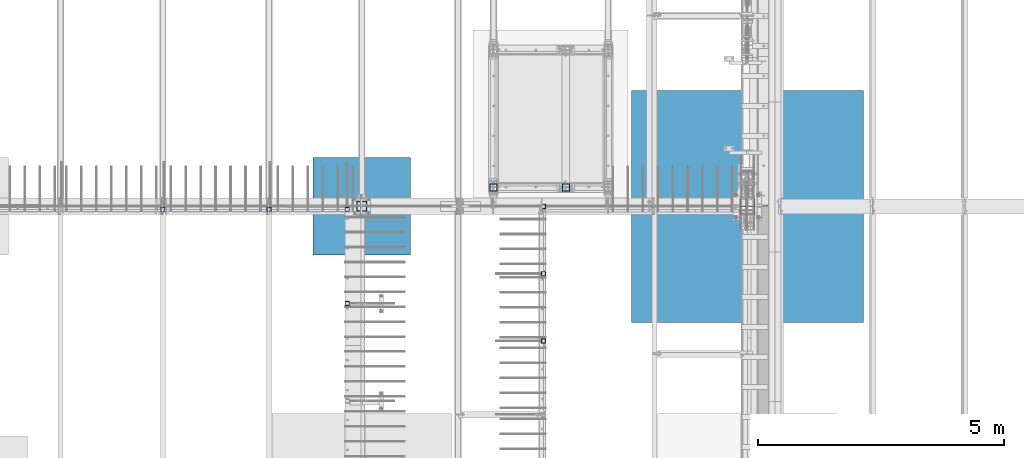
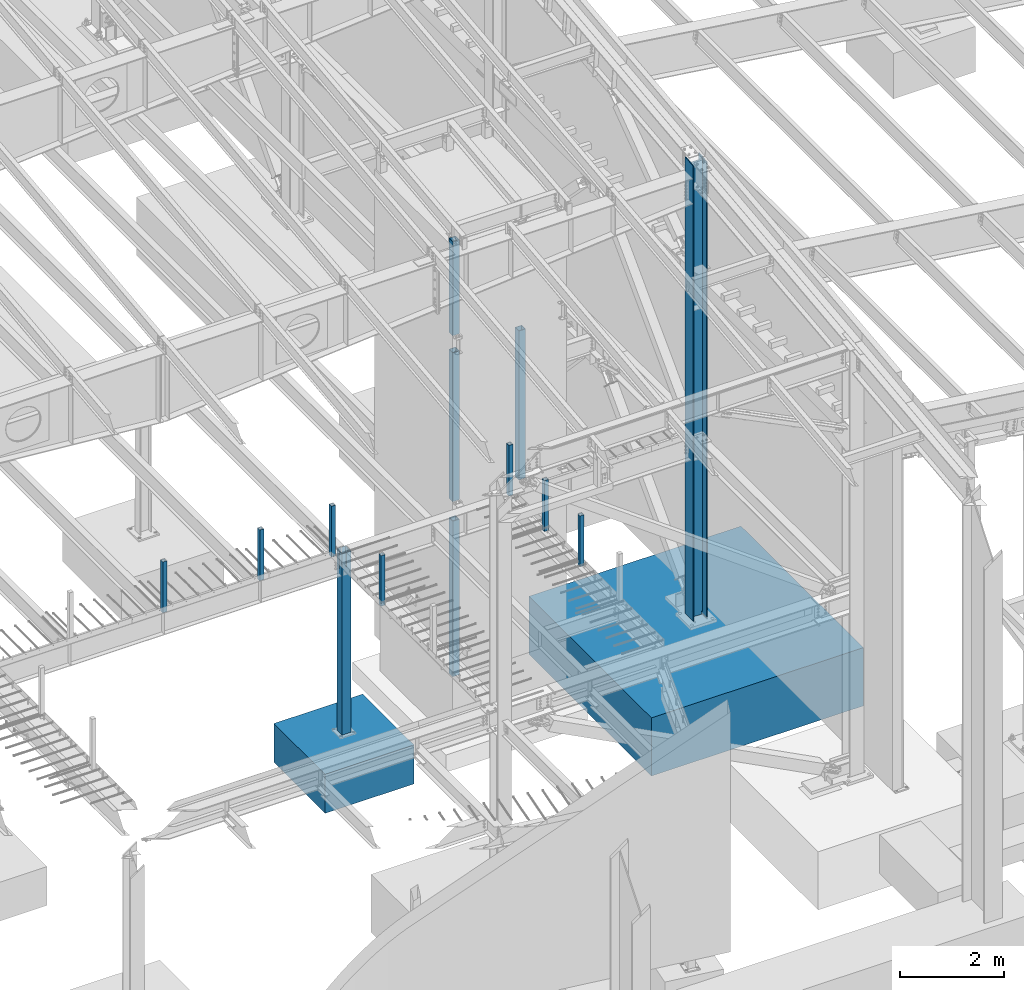
# One storey, part 355 of 1179: 15 columns, 15 elements without a shape of their own.
"""IFC2X3 building model written with IfcOpenShell, lengths in millimetres."""

from ifc_helpers import new_model, si_unit, frame, origin_with_axes, place, context, subcontext, project, spatial, faceted_brep, material, type_object, element, aggregate, save


model = new_model("IFC2X3")

# Units and contexts
model_context = context("Model", 3, precision=1e-05, world=origin_with_axes())
body_context = subcontext(model_context, "Body", "Model", "MODEL_VIEW")
ifc_project = project(units=[si_unit("LENGTHUNIT", "METRE", prefix="MILLI"), si_unit("AREAUNIT", "SQUARE_METRE"), si_unit("VOLUMEUNIT", "CUBIC_METRE"), si_unit("MASSUNIT", "GRAM", prefix="KILO"), si_unit("TIMEUNIT", "SECOND"), si_unit("PLANEANGLEUNIT", "RADIAN"), si_unit("SOLIDANGLEUNIT", "STERADIAN"), si_unit("THERMODYNAMICTEMPERATUREUNIT", "DEGREE_CELSIUS"), si_unit("LUMINOUSINTENSITYUNIT", "LUMEN")], contexts=[model_context])

# Site, building, storey
site_placement = place(None, origin_with_axes())
site = spatial("IfcSite", under=ifc_project, at=site_placement, CompositionType="ELEMENT")
building_placement = place(site_placement, origin_with_axes())
building = spatial("IfcBuilding", under=site, at=building_placement, Name="Undefined", CompositionType="ELEMENT")
storey_placement = place(building_placement, origin_with_axes())
storey = spatial("IfcBuildingStorey", under=building, at=storey_placement, Name="Undefined", CompositionType="ELEMENT", Elevation=0.0)

# Assembly, column
assembly_1_placement = place(storey_placement, origin_with_axes())
assembly_1 = element("IfcElementAssembly", 1, at=assembly_1_placement, inside=storey, Name="COLUMN", AssemblyPlace="NOTDEFINED", PredefinedType="RIGID_FRAME")
ifc_material_1 = material()
column_type_1 = type_object("IfcColumnType", Name="HSS6X6X3/8", PredefinedType="NOTDEFINED")
column_1_placement = place(assembly_1_placement, frame((19138.9, 11868.15, 4102.1), z_axis=(0.0, 1.0, 0.0), x_axis=(0.0, 0.0, 1.0)))
column_1 = element("IfcColumn", 2, at=column_1_placement, type_object=column_type_1, material=ifc_material_1, Name="COLUMN", ObjectType="HSS6X6X3/8", context=body_context, shape_type="Brep", body=[
    faceted_brep([(19.0500000000002, 66.6749999999993, -66.6749999999993), (19.0500000000002, -66.6749999999993, -66.6749999999993), (3524.25, -66.6749999999993, -66.6749999999993), (3524.25, 66.6749999999993, -66.6749999999993), (19.0500000000002, -66.6749999999993, 66.6749999999993), (3524.25, -66.6749999999993, 66.6749999999993), (19.0500000000002, 66.6749999999993, 66.6749999999993), (3524.25, 66.6749999999993, 66.6749999999993), (19.0500000000002, 76.2000000000007, -76.2000000000007), (19.0500000000002, 76.2000000000007, 76.2000000000007), (3524.25, 76.2000000000007, 76.2000000000007), (3524.25, 76.2000000000007, -76.2000000000007), (19.0500000000002, -76.2000000000007, 76.2000000000007), (3524.25, -76.2000000000007, 76.2000000000007), (19.0500000000002, -76.2000000000007, -76.2000000000007), (3524.25, -76.2000000000007, -76.2000000000007)], [[[0, 1, 2, 3]], [[1, 4, 5, 2]], [[4, 6, 7, 5]], [[6, 0, 3, 7]], [[8, 9, 10, 11]], [[9, 12, 13, 10]], [[12, 14, 15, 13]], [[14, 8, 11, 15]], [[13, 15, 11, 10], [5, 7, 3, 2]], [[14, 12, 9, 8], [6, 4, 1, 0]]]),
])
aggregate(assembly_1, [column_1])

assembly_2_placement = place(storey_placement, origin_with_axes())
assembly_2 = element("IfcElementAssembly", 3, at=assembly_2_placement, inside=storey, Name="COLUMN", AssemblyPlace="NOTDEFINED", PredefinedType="RIGID_FRAME")
column_2_placement = place(assembly_2_placement, frame((20612.1, 11868.15, 4102.1), z_axis=(0.0, 1.0, 0.0), x_axis=(0.0, 0.0, 1.0)))
column_2 = element("IfcColumn", 4, at=column_2_placement, type_object=column_type_1, material=ifc_material_1, Name="COLUMN", ObjectType="HSS6X6X3/8", context=body_context, shape_type="Brep", body=[
    faceted_brep([(19.0500000000002, 66.6749999999993, -66.6749999999993), (19.0500000000002, -66.6749999999993, -66.6749999999993), (3524.25, -66.6749999999993, -66.6749999999993), (3524.25, 66.6749999999993, -66.6749999999993), (19.0500000000002, -66.6749999999993, 66.6749999999993), (3524.25, -66.6749999999993, 66.6749999999993), (19.0500000000002, 66.6749999999993, 66.6749999999993), (3524.25, 66.6749999999993, 66.6749999999993), (19.0500000000002, 76.2000000000007, -76.2000000000007), (19.0500000000002, 76.2000000000007, 76.2000000000007), (3524.25, 76.2000000000007, 76.2000000000007), (3524.25, 76.2000000000007, -76.2000000000007), (19.0500000000002, -76.2000000000007, 76.2000000000007), (3524.25, -76.2000000000007, 76.2000000000007), (19.0500000000002, -76.2000000000007, -76.2000000000007), (3524.25, -76.2000000000007, -76.2000000000007)], [[[0, 1, 2, 3]], [[1, 4, 5, 2]], [[4, 6, 7, 5]], [[6, 0, 3, 7]], [[8, 9, 10, 11]], [[9, 12, 13, 10]], [[12, 14, 15, 13]], [[14, 8, 11, 15]], [[13, 15, 11, 10], [5, 7, 3, 2]], [[14, 12, 9, 8], [6, 4, 1, 0]]]),
])
aggregate(assembly_2, [column_2])

assembly_3_placement = place(storey_placement, origin_with_axes())
assembly_3 = element("IfcElementAssembly", 5, at=assembly_3_placement, inside=storey, Name="COLUMN", AssemblyPlace="NOTDEFINED", PredefinedType="RIGID_FRAME")
column_3_placement = place(assembly_3_placement, frame((19138.9, 11868.15, 8013.7), z_axis=(0.0, 1.0, 0.0), x_axis=(0.0, 0.0, 1.0)))
column_3 = element("IfcColumn", 6, at=column_3_placement, type_object=column_type_1, material=ifc_material_1, Name="COLUMN", ObjectType="HSS6X6X3/8", context=body_context, shape_type="Brep", body=[
    faceted_brep([(19.0500000000002, 66.6749999999993, -66.6749999999993), (19.0500000000002, -66.6749999999993, -66.6749999999993), (2231.40317592474, -66.6749999999993, -66.6749999999993), (2231.40317592474, 66.6749999999993, -66.6749999999993), (19.0500000000002, -66.6749999999993, 66.6749999999993), (2231.40317592474, -66.6749999999993, 66.6749999999993), (19.0500000000002, 66.6749999999993, 66.6749999999993), (2231.40317592474, 66.6749999999993, 66.6749999999993), (19.0500000000002, 76.2000000000007, -76.2000000000007), (19.0500000000002, 76.2000000000007, 76.2000000000007), (2231.40317592474, 76.2000000000007, 76.2000000000007), (2231.40317592474, 76.2000000000007, -76.2000000000007), (19.0500000000002, -76.2000000000007, 76.2000000000007), (2231.40317592474, -76.2000000000007, 76.2000000000007), (19.0500000000002, -76.2000000000007, -76.2000000000007), (2231.40317592474, -76.2000000000007, -76.2000000000007)], [[[0, 1, 2, 3]], [[1, 4, 5, 2]], [[4, 6, 7, 5]], [[6, 0, 3, 7]], [[8, 9, 10, 11]], [[9, 12, 13, 10]], [[12, 14, 15, 13]], [[14, 8, 11, 15]], [[13, 15, 11, 10], [5, 7, 3, 2]], [[14, 12, 9, 8], [6, 4, 1, 0]]]),
])
aggregate(assembly_3, [column_3])

assembly_4_placement = place(storey_placement, origin_with_axes())
assembly_4 = element("IfcElementAssembly", 7, at=assembly_4_placement, inside=storey, Name="COLUMN", AssemblyPlace="NOTDEFINED", PredefinedType="RIGID_FRAME")
column_type_2 = type_object("IfcColumnType", Name="HSS6X6X5/8", PredefinedType="NOTDEFINED")
column_4_placement = place(assembly_4_placement, frame((19138.9, 11868.15, 0.0), z_axis=(0.0, 1.0, 0.0), x_axis=(0.0, 0.0, 1.0)))
column_4 = element("IfcColumn", 8, at=column_4_placement, type_object=column_type_2, material=ifc_material_1, Name="COLUMN", ObjectType="HSS6X6X5/8", context=body_context, shape_type="Brep", body=[
    faceted_brep([(0.0, 60.3250000000007, -60.3250000000007), (2.71050543121376e-20, -60.3250000000007, -60.3250000000007), (3660.775, -60.325000001314, -60.3250000000007), (3660.775, 60.3249999986838, -60.3250000000007), (2.71050543121376e-20, -60.3250000000007, 60.3250000000007), (3660.775, -60.325000001314, 60.3250000000007), (0.0, 60.3250000000007, 60.3250000000007), (3660.775, 60.3249999986838, 60.3250000000007), (6.54836185276508e-11, 76.2, -76.1999999999998), (6.54836185276508e-11, 76.2, 76.1999999999998), (3660.775, 76.1999999986838, 76.2000000000007), (3660.775, 76.1999999986838, -76.2000000000007), (-6.54836185276508e-11, -76.2, 76.1999999999998), (3660.775, -76.200000001314, 76.2000000000007), (-6.54836185276508e-11, -76.2, -76.1999999999998), (3660.775, -76.200000001314, -76.2000000000007)], [[[0, 1, 2, 3]], [[1, 4, 5, 2]], [[4, 6, 7, 5]], [[6, 0, 3, 7]], [[8, 9, 10, 11]], [[9, 12, 13, 10]], [[12, 14, 15, 13]], [[14, 8, 11, 15]], [[13, 15, 11, 10], [5, 7, 3, 2]], [[14, 12, 9, 8], [6, 4, 1, 0]]]),
])
aggregate(assembly_4, [column_4])

assembly_5_placement = place(storey_placement, origin_with_axes())
assembly_5 = element("IfcElementAssembly", 9, at=assembly_5_placement, inside=storey, Name="COLUMN", AssemblyPlace="NOTDEFINED", PredefinedType="RIGID_FRAME")
column_type_3 = type_object("IfcColumnType", Name="HSS3-1/2X3-1/2X5/16", PredefinedType="NOTDEFINED")
column_5_placement = place(assembly_5_placement, frame((14566.9, 11420.475, 4102.1), z_axis=(0.0, 1.0, 0.0), x_axis=(0.0, 0.0, 1.0)))
column_5 = element("IfcColumn", 10, at=column_5_placement, type_object=column_type_3, material=ifc_material_1, Name="COLUMN", ObjectType="HSS3-1/2X3-1/2X5/16", context=body_context, shape_type="Brep", body=[
    faceted_brep([(0.0, 36.5125000000007, -36.5125000000007), (0.0, -36.5125000000007, -36.5125000000007), (1195.387, -36.5125000000007, -36.5125000000007), (1195.387, 36.5125000000007, -36.5125000000007), (0.0, -36.5125000000007, 36.5125000000007), (1195.387, -36.5125000000007, 36.5125000000007), (0.0, 36.5125000000007, 36.5125000000007), (1195.387, 36.5125000000007, 36.5125000000007), (0.0, 44.4500000000007, -44.4499999999998), (0.0, 44.4500000000007, 44.4500000000007), (1195.387, 44.4500000000007, 44.4500000000007), (1195.387, 44.4500000000007, -44.4500000000007), (0.0, -44.4500000000007, 44.4500000000007), (1195.387, -44.4500000000007, 44.4500000000007), (0.0, -44.4500000000007, -44.4500000000007), (1195.387, -44.4500000000007, -44.4500000000007)], [[[0, 1, 2, 3]], [[1, 4, 5, 2]], [[4, 6, 7, 5]], [[6, 0, 3, 7]], [[8, 9, 10, 11]], [[9, 12, 13, 10]], [[12, 14, 15, 13]], [[14, 8, 11, 15]], [[13, 15, 11, 10], [5, 7, 3, 2]], [[14, 12, 9, 8], [6, 4, 1, 0]]]),
])
aggregate(assembly_5, [column_5])

assembly_6_placement = place(storey_placement, origin_with_axes())
assembly_6 = element("IfcElementAssembly", 11, at=assembly_6_placement, inside=storey, Name="COLUMN", AssemblyPlace="NOTDEFINED", PredefinedType="RIGID_FRAME")
column_6_placement = place(assembly_6_placement, frame((12407.9, 11420.475, 4102.1), z_axis=(0.0, 1.0, 0.0), x_axis=(0.0, 0.0, 1.0)))
column_6 = element("IfcColumn", 12, at=column_6_placement, type_object=column_type_3, material=ifc_material_1, Name="COLUMN", ObjectType="HSS3-1/2X3-1/2X5/16", context=body_context, shape_type="Brep", body=[
    faceted_brep([(0.0, 36.5125000000007, -36.5125000000007), (0.0, -36.5125000000007, -36.5125000000007), (1195.387, -36.5125000000007, -36.5125000000007), (1195.387, 36.5125000000007, -36.5125000000007), (0.0, -36.5125000000007, 36.5125000000007), (1195.387, -36.5125000000007, 36.5125000000007), (0.0, 36.5125000000007, 36.5125000000007), (1195.387, 36.5125000000007, 36.5125000000007), (0.0, 44.4500000000007, -44.4499999999998), (0.0, 44.4500000000007, 44.4500000000007), (1195.387, 44.4500000000007, 44.4500000000007), (1195.387, 44.4500000000007, -44.4500000000007), (0.0, -44.4500000000007, 44.4500000000007), (1195.387, -44.4500000000007, 44.4500000000007), (0.0, -44.4500000000007, -44.4500000000007), (1195.387, -44.4500000000007, -44.4500000000007)], [[[0, 1, 2, 3]], [[1, 4, 5, 2]], [[4, 6, 7, 5]], [[6, 0, 3, 7]], [[8, 9, 10, 11]], [[9, 12, 13, 10]], [[12, 14, 15, 13]], [[14, 8, 11, 15]], [[13, 15, 11, 10], [5, 7, 3, 2]], [[14, 12, 9, 8], [6, 4, 1, 0]]]),
])
aggregate(assembly_6, [column_6])

assembly_7_placement = place(storey_placement, origin_with_axes())
assembly_7 = element("IfcElementAssembly", 13, at=assembly_7_placement, inside=storey, Name="COLUMN", AssemblyPlace="NOTDEFINED", PredefinedType="RIGID_FRAME")
column_7_placement = place(assembly_7_placement, frame((16163.925, 9499.6, 4108.45000000005), z_axis=(0.0, 1.0, 0.0), x_axis=(0.0, 0.0, 1.0)))
column_7 = element("IfcColumn", 14, at=column_7_placement, type_object=column_type_3, material=ifc_material_1, Name="COLUMN", ObjectType="HSS3-1/2X3-1/2X5/16", context=body_context, shape_type="Brep", body=[
    faceted_brep([(0.0, 36.5125000000007, -36.5125000000007), (0.0, -36.5125000000007, -36.5125000000007), (1189.03749999998, -36.5125000000007, -36.5124999999998), (1189.03749999998, 36.5125000000007, -36.5124999999998), (0.0, -36.5125000000007, 36.5125000000007), (1189.03749999998, -36.5125000000007, 36.5124999999998), (0.0, 36.5125000000007, 36.5125000000007), (1189.03749999998, 36.5125000000007, 36.5124999999998), (0.0, 44.4500000000007, -44.4499999999998), (0.0, 44.4500000000007, 44.4500000000007), (1189.03749999998, 44.4500000000007, 44.4499999999998), (1189.03749999998, 44.4500000000007, -44.4499999999998), (0.0, -44.4500000000007, 44.4500000000007), (1189.03749999998, -44.4500000000007, 44.4499999999998), (0.0, -44.4500000000007, -44.4500000000007), (1189.03749999998, -44.4500000000007, -44.4499999999998)], [[[0, 1, 2, 3]], [[1, 4, 5, 2]], [[4, 6, 7, 5]], [[6, 0, 3, 7]], [[8, 9, 10, 11]], [[9, 12, 13, 10]], [[12, 14, 15, 13]], [[14, 8, 11, 15]], [[13, 15, 11, 10], [5, 7, 3, 2]], [[14, 12, 9, 8], [6, 4, 1, 0]]]),
])
aggregate(assembly_7, [column_7])

assembly_8_placement = place(storey_placement, origin_with_axes())
assembly_8 = element("IfcElementAssembly", 15, at=assembly_8_placement, inside=storey, Name="COLUMN", AssemblyPlace="NOTDEFINED", PredefinedType="RIGID_FRAME")
column_8_placement = place(assembly_8_placement, frame((16163.925, 11420.475, 4102.1), z_axis=(0.0, 1.0, 0.0), x_axis=(0.0, 0.0, 1.0)))
column_8 = element("IfcColumn", 16, at=column_8_placement, type_object=column_type_3, material=ifc_material_1, Name="COLUMN", ObjectType="HSS3-1/2X3-1/2X5/16", context=body_context, shape_type="Brep", body=[
    faceted_brep([(0.0, 36.5125000000007, -36.5125000000007), (0.0, -36.5125000000007, -36.5125000000007), (1195.387, -36.5125000000007, -36.5125000000007), (1195.387, 36.5125000000007, -36.5125000000007), (0.0, -36.5125000000007, 36.5125000000007), (1195.387, -36.5125000000007, 36.5125000000007), (0.0, 36.5125000000007, 36.5125000000007), (1195.387, 36.5125000000007, 36.5125000000007), (0.0, 44.4500000000007, -44.4499999999998), (0.0, 44.4500000000007, 44.4500000000007), (1195.387, 44.4500000000007, 44.4500000000007), (1195.387, 44.4500000000007, -44.4500000000007), (0.0, -44.4500000000007, 44.4500000000007), (1195.387, -44.4500000000007, 44.4500000000007), (0.0, -44.4500000000007, -44.4500000000007), (1195.387, -44.4500000000007, -44.4500000000007)], [[[0, 1, 2, 3]], [[1, 4, 5, 2]], [[4, 6, 7, 5]], [[6, 0, 3, 7]], [[8, 9, 10, 11]], [[9, 12, 13, 10]], [[12, 14, 15, 13]], [[14, 8, 11, 15]], [[13, 15, 11, 10], [5, 7, 3, 2]], [[14, 12, 9, 8], [6, 4, 1, 0]]]),
])
aggregate(assembly_8, [column_8])

assembly_9_placement = place(storey_placement, origin_with_axes())
assembly_9 = element("IfcElementAssembly", 17, at=assembly_9_placement, inside=storey, Name="COLUMN", AssemblyPlace="NOTDEFINED", PredefinedType="RIGID_FRAME")
column_9_placement = place(assembly_9_placement, frame((20154.9, 8737.6, 4102.1), z_axis=(0.0, 1.0, 0.0), x_axis=(0.0, 0.0, 1.0)))
column_9 = element("IfcColumn", 18, at=column_9_placement, type_object=column_type_3, material=ifc_material_1, Name="COLUMN", ObjectType="HSS3-1/2X3-1/2X5/16", context=body_context, shape_type="Brep", body=[
    faceted_brep([(0.0, 36.5125000000007, -36.5125000000007), (0.0, -36.5125000000007, -36.5125000000007), (1195.387, -36.5125000000007, -36.5125000000007), (1195.387, 36.5125000000007, -36.5125000000007), (0.0, -36.5125000000007, 36.5125000000007), (1195.387, -36.5125000000007, 36.5125000000007), (0.0, 36.5125000000007, 36.5125000000007), (1195.387, 36.5125000000007, 36.5125000000007), (0.0, 44.4500000000007, -44.4499999999998), (0.0, 44.4500000000007, 44.4500000000007), (1195.387, 44.4500000000007, 44.4500000000007), (1195.387, 44.4500000000007, -44.4500000000007), (0.0, -44.4500000000007, 44.4500000000007), (1195.387, -44.4500000000007, 44.4500000000007), (0.0, -44.4500000000007, -44.4500000000007), (1195.387, -44.4500000000007, -44.4500000000007)], [[[0, 1, 2, 3]], [[1, 4, 5, 2]], [[4, 6, 7, 5]], [[6, 0, 3, 7]], [[8, 9, 10, 11]], [[9, 12, 13, 10]], [[12, 14, 15, 13]], [[14, 8, 11, 15]], [[13, 15, 11, 10], [5, 7, 3, 2]], [[14, 12, 9, 8], [6, 4, 1, 0]]]),
])
aggregate(assembly_9, [column_9])

assembly_10_placement = place(storey_placement, origin_with_axes())
assembly_10 = element("IfcElementAssembly", 19, at=assembly_10_placement, inside=storey, Name="COLUMN", AssemblyPlace="NOTDEFINED", PredefinedType="RIGID_FRAME")
column_10_placement = place(assembly_10_placement, frame((20154.9, 10109.2, 4102.1), z_axis=(0.0, 1.0, 0.0), x_axis=(0.0, 0.0, 1.0)))
column_10 = element("IfcColumn", 20, at=column_10_placement, type_object=column_type_3, material=ifc_material_1, Name="COLUMN", ObjectType="HSS3-1/2X3-1/2X5/16", context=body_context, shape_type="Brep", body=[
    faceted_brep([(0.0, 36.5125000000007, -36.5125000000007), (0.0, -36.5125000000007, -36.5125000000007), (1195.387, -36.5125000000007, -36.5125000000007), (1195.387, 36.5125000000007, -36.5125000000007), (0.0, -36.5125000000007, 36.5125000000007), (1195.387, -36.5125000000007, 36.5125000000007), (0.0, 36.5125000000007, 36.5125000000007), (1195.387, 36.5125000000007, 36.5125000000007), (0.0, 44.4500000000007, -44.4499999999998), (0.0, 44.4500000000007, 44.4500000000007), (1195.387, 44.4500000000007, 44.4500000000007), (1195.387, 44.4500000000007, -44.4500000000007), (0.0, -44.4500000000007, 44.4500000000007), (1195.387, -44.4500000000007, 44.4500000000007), (0.0, -44.4500000000007, -44.4500000000007), (1195.387, -44.4500000000007, -44.4500000000007)], [[[0, 1, 2, 3]], [[1, 4, 5, 2]], [[4, 6, 7, 5]], [[6, 0, 3, 7]], [[8, 9, 10, 11]], [[9, 12, 13, 10]], [[12, 14, 15, 13]], [[14, 8, 11, 15]], [[13, 15, 11, 10], [5, 7, 3, 2]], [[14, 12, 9, 8], [6, 4, 1, 0]]]),
])
aggregate(assembly_10, [column_10])

assembly_11_placement = place(storey_placement, origin_with_axes())
assembly_11 = element("IfcElementAssembly", 21, at=assembly_11_placement, inside=storey, Name="COLUMN", AssemblyPlace="NOTDEFINED", PredefinedType="RIGID_FRAME")
column_11_placement = place(assembly_11_placement, frame((20154.9, 11480.8, 4102.1), z_axis=(0.0, 1.0, 0.0), x_axis=(0.0, 0.0, 1.0)))
column_11 = element("IfcColumn", 22, at=column_11_placement, type_object=column_type_3, material=ifc_material_1, Name="COLUMN", ObjectType="HSS3-1/2X3-1/2X5/16", context=body_context, shape_type="Brep", body=[
    faceted_brep([(0.0, 36.5125000000007, -36.5125000000007), (0.0, -36.5125000000007, -36.5125000000007), (1195.387, -36.5125000000007, -36.5125000000007), (1195.387, 36.5125000000007, -36.5125000000007), (0.0, -36.5125000000007, 36.5125000000007), (1195.387, -36.5125000000007, 36.5125000000007), (0.0, 36.5125000000007, 36.5125000000007), (1195.387, 36.5125000000007, 36.5125000000007), (0.0, 44.4500000000007, -44.4499999999998), (0.0, 44.4500000000007, 44.4500000000007), (1195.387, 44.4500000000007, 44.4500000000007), (1195.387, 44.4500000000007, -44.4500000000007), (0.0, -44.4500000000007, 44.4500000000007), (1195.387, -44.4500000000007, 44.4500000000007), (0.0, -44.4500000000007, -44.4500000000007), (1195.387, -44.4500000000007, -44.4500000000007)], [[[0, 1, 2, 3]], [[1, 4, 5, 2]], [[4, 6, 7, 5]], [[6, 0, 3, 7]], [[8, 9, 10, 11]], [[9, 12, 13, 10]], [[12, 14, 15, 13]], [[14, 8, 11, 15]], [[13, 15, 11, 10], [5, 7, 3, 2]], [[14, 12, 9, 8], [6, 4, 1, 0]]]),
])
aggregate(assembly_11, [column_11])

assembly_12_placement = place(storey_placement, origin_with_axes())
assembly_12 = element("IfcElementAssembly", 23, at=assembly_12_placement, inside=storey, Name="FOOTING", AssemblyPlace="NOTDEFINED", PredefinedType="REINFORCEMENT_UNIT")
ifc_material_2 = material(Name="CONCRETE/3000")
column_type_4 = type_object("IfcColumnType", PredefinedType="NOTDEFINED")
column_12_placement = place(assembly_12_placement, frame((24307.8, 11480.8, -1727.2), z_axis=(-1.0, 0.0, 0.0), x_axis=(0.0, 0.0, 1.0)))
column_12 = element("IfcColumn", 24, at=column_12_placement, type_object=column_type_4, material=ifc_material_2, Name="FOOTING", context=body_context, shape_type="Brep", body=[
    faceted_brep([(0.0, 2362.2, -2362.2), (0.0, 2362.2, 2362.2), (1371.6, 2362.2, 2362.2), (1371.6, 2362.2, -2362.2), (0.0, -2362.2, 2362.2), (1371.6, -2362.2, 2362.2), (0.0, -2362.2, -2362.2), (1371.6, -2362.2, -2362.2)], [[[0, 1, 2, 3]], [[1, 4, 5, 2]], [[4, 6, 7, 5]], [[6, 0, 3, 7]], [[5, 7, 3, 2]], [[6, 4, 1, 0]]]),
])
aggregate(assembly_12, [column_12])

assembly_13_placement = place(storey_placement, origin_with_axes())
assembly_13 = element("IfcElementAssembly", 25, at=assembly_13_placement, inside=storey, Name="FOOTING", AssemblyPlace="NOTDEFINED", PredefinedType="REINFORCEMENT_UNIT")
column_type_5 = type_object("IfcColumnType", PredefinedType="NOTDEFINED")
column_13_placement = place(assembly_13_placement, frame((16459.2, 11480.8, -1168.4), z_axis=(-1.0, 0.0, 0.0), x_axis=(0.0, 0.0, 1.0)))
column_13 = element("IfcColumn", 26, at=column_13_placement, type_object=column_type_5, material=ifc_material_2, Name="FOOTING", context=body_context, shape_type="Brep", body=[
    faceted_brep([(0.0, 990.6, -990.599999999999), (0.0, 990.6, 990.6), (914.4, 990.6, 990.6), (914.4, 990.6, -990.599999999999), (0.0, -990.6, 990.6), (914.4, -990.6, 990.6), (0.0, -990.6, -990.599999999999), (914.4, -990.6, -990.599999999999)], [[[0, 1, 2, 3]], [[1, 4, 5, 2]], [[4, 6, 7, 5]], [[6, 0, 3, 7]], [[5, 7, 3, 2]], [[6, 4, 1, 0]]]),
])
aggregate(assembly_13, [column_13])

assembly_14_placement = place(storey_placement, origin_with_axes())
assembly_14 = element("IfcElementAssembly", 27, at=assembly_14_placement, inside=storey, Name="COLUMN", AssemblyPlace="NOTDEFINED", PredefinedType="RIGID_FRAME")
ifc_material_3 = material(Name="STEEL/A992")
column_type_6 = type_object("IfcColumnType", Name="W12X79", PredefinedType="NOTDEFINED")
column_14_placement = place(assembly_14_placement, frame((24307.8, 11480.8, -355.6), z_axis=(-1.0, 0.0, 0.0), x_axis=(0.0, 0.0, 1.0)))
column_14 = element("IfcColumn", 28, at=column_14_placement, type_object=column_type_6, material=ifc_material_3, Name="COLUMN", ObjectType="W12X79", context=body_context, shape_type="Brep", body=[
    faceted_brep([(160.223581529497, -153.987499999999, 157.1625), (160.223581529497, 153.987499999999, 157.1625), (149.225002356772, 153.987499999999, 138.1125), (149.225002356772, 6.35000012494493, 138.1125), (148.995793121516, 6.35000012313685, 137.715499999996), (148.995793121516, -6.34999999999854, 137.715499999996), (149.225002356772, -6.34999999999854, 138.1125), (149.225002356772, -153.987499999999, 138.1125), (188.913, -6.34999999999854, 137.715499999996), (188.913, 6.35000008947463, 137.715499999996), (208.49066058208, 6.35000008789211, 131.2871410688), (208.49066058208, -6.34999999999854, 131.2871410688), (212.873373738864, 6.35000008718271, 128.290736246858), (212.873373738864, -6.34999999999854, 128.290736246858), (214.971292158606, 6.35000008606585, 123.413713099926), (214.971292158606, -6.34999999999854, 123.413713099926), (214.132634973196, 6.3500000848835, 118.171264187733), (214.132634973196, -6.34999999999854, 118.171264187733), (210.617956026487, 6.35000008400311, 114.192112472459), (210.617956026487, -6.34999999999854, 114.192112472459), (205.519195059062, 6.35000008370116, 112.712499999996), (205.519195059062, -6.34999999999854, 112.712499999996), (139.700000000001, 6.34999999999854, 112.7125), (147.032309983244, -6.35000007376584, 112.7125), (139.700000000001, 6.34999999999854, -112.7125), (147.032309983244, -6.35000000747095, -112.7125), (205.519195059063, 6.3500000365857, -112.712500000003), (205.519195059063, -6.34999999999854, -112.712500000003), (210.617956026486, 6.35000003621826, -114.192112472468), (210.617956026486, -6.34999999999854, -114.192112472468), (214.132634973195, 6.35000003529422, -118.171264187741), (214.132634973195, -6.34999999999854, -118.171264187741), (214.971292158605, 6.35000003410096, -123.413713099934), (214.971292158605, -6.34999999999854, -123.413713099934), (212.873373738863, 6.35000003300956, -128.290736246865), (212.873373738863, -6.34999999999854, -128.290736246865), (208.49066058208, 6.35000003235837, -131.287141068808), (208.49066058208, -6.34999999999854, -131.287141068808), (188.913, 6.35000003102323, -137.715500000003), (188.913, -6.34999999999854, -137.715500000003), (148.99620123074, 6.35000000162472, -137.715500000003), (148.99620123074, -6.34999999999854, -137.715500000003), (10871.7701032848, 6.35000000000036, -138.112499999999), (10900.5064502286, 6.35000000000036, -138.112499999999), (10917.1798573464, 153.987499999999, -138.112499999999), (149.225402461476, 153.987499999999, -138.1125), (149.225402461477, 6.34999999999854, -138.1125), (10882.3987715308, -153.987499999999, -138.112499999999), (10882.3987715308, -153.987499999999, -157.162499999999), (10917.1798573464, 153.987499999999, -157.162499999999), (10899.0721786486, -6.35000000000036, -138.112499999999), (149.225402461476, -153.987499999999, -138.1125), (160.223597538519, -153.987499999999, -157.1625), (160.223597538519, 153.987499999999, -157.1625), (149.225402461476, -6.34999999999854, -138.1125), (10870.3358317079, -6.35000000000036, -138.112499999999), (10871.7701032848, 6.35000000000036, 138.112499999999), (10870.3358317079, -6.35000000021682, 138.112499999999), (10900.5024442939, 6.35000002950983, 138.112499999999), (10899.0721786486, -6.35000000000036, 138.112499999999), (10917.1798573464, 153.987499999999, 138.112499999999), (10917.1798573464, 153.987499999999, 157.162499999999), (10882.3987715308, -153.987499999999, 157.162499999999), (10882.3987715308, -153.987499999999, 138.112499999999)], [[[0, 1, 2, 3, 4, 5, 6, 7]], [[8, 9, 10, 11]], [[11, 10, 12, 13]], [[13, 12, 14, 15]], [[15, 14, 16, 17]], [[17, 16, 18, 19]], [[19, 18, 20, 21]], [[21, 20, 22, 23]], [[24, 25, 23, 22]], [[25, 24, 26, 27]], [[27, 26, 28, 29]], [[29, 28, 30, 31]], [[31, 30, 32, 33]], [[33, 32, 34, 35]], [[35, 34, 36, 37]], [[37, 36, 38, 39]], [[39, 38, 40, 41]], [[42, 43, 44, 45, 46]], [[47, 48, 49, 44, 43, 50]], [[48, 47, 51, 52]], [[49, 48, 52, 53]], [[44, 49, 53, 45]], [[52, 51, 54, 41, 40, 46, 45, 53]], [[47, 50, 55, 54, 51]], [[43, 42, 55, 50]], [[56, 57, 55, 42]], [[58, 59, 57, 56]], [[60, 61, 62, 63, 59, 58]], [[63, 62, 0, 7]], [[57, 59, 63, 7, 6]], [[8, 11, 13, 15, 17, 19, 21, 23, 25, 27, 29, 31, 33, 35, 37, 39, 41, 54, 55, 57, 6, 5]], [[9, 8, 5, 4]], [[56, 42, 46, 40, 38, 36, 34, 32, 30, 28, 26, 24, 22, 20, 18, 16, 14, 12, 10, 9, 4, 3]], [[60, 58, 56, 3, 2]], [[61, 60, 2, 1]], [[62, 61, 1, 0]]]),
])
aggregate(assembly_14, [column_14])

assembly_15_placement = place(storey_placement, origin_with_axes())
assembly_15 = element("IfcElementAssembly", 29, at=assembly_15_placement, inside=storey, Name="COLUMN", AssemblyPlace="NOTDEFINED", PredefinedType="RIGID_FRAME")
column_type_7 = type_object("IfcColumnType", Name="HSS8X8X3/8", PredefinedType="NOTDEFINED")
column_15_placement = place(assembly_15_placement, frame((16459.2, 11480.8, -355.6), z_axis=(0.0, 1.0, 0.0), x_axis=(0.0, 0.0, 1.0)))
column_15 = element("IfcColumn", 30, at=column_15_placement, type_object=column_type_7, material=ifc_material_1, Name="COLUMN", ObjectType="HSS8X8X3/8", context=body_context, shape_type="Brep", body=[
    faceted_brep([(4451.35, -1.58750000000509, 101.6), (4116.38749990463, -1.58750000000509, 101.6), (4116.38749990463, -1.58750000000509, 92.0750000000007), (4451.35, -1.58750000000509, 92.0750000000007), (4113.95746014561, -2.07086496130069, 101.6), (4113.95746014561, -2.07086496130069, 92.0750000000007), (4111.89737191153, -3.44737191153763, 101.6), (4111.89737191153, -3.44737191153763, 92.0750000000007), (4110.5208649613, -5.50746014561446, 101.6), (4110.5208649613, -5.50746014561446, 92.0750000000007), (4110.0375, -7.93750009536961, 101.6), (4110.0375, -7.93750009536961, 92.0750000000007), (4110.5208649613, -10.3675398543928, 101.6), (4110.5208649613, -10.3675398543928, 92.0750000000007), (4111.89737191153, -12.4276280884696, 101.6), (4111.89737191153, -12.4276280884696, 92.0750000000007), (4113.95746014561, -13.8041350387066, 101.6), (4113.95746014561, -13.8041350387066, 92.0750000000007), (4116.38749990463, -14.2875000000022, 101.6), (4116.38749990463, -14.2875000000022, 92.0750000000007), (4451.35000009537, -14.2875000000022, 101.6), (4451.35, -14.2875000000022, 92.0750000000007), (4037.75746014561, -101.6, 15.391635038708), (4037.75746014561, -92.0750000000007, 15.391635038708), (4040.18749990463, -92.0750000000007, 15.8750000000018), (4040.18749990463, -101.6, 15.8750000000018), (4035.69737191153, -101.6, 14.0151280884693), (4035.69737191153, -92.0750000000007, 14.0151280884693), (4034.32086496129, -101.6, 11.9550398543925), (4034.32086496129, -92.0750000000007, 11.9550398543925), (4033.8375, -101.6, 9.52500009536925), (4033.8375, -92.0750000000007, 9.52500009536925), (4034.32086496129, -101.6, 7.09496014561046), (4034.32086496129, -92.0750000000007, 7.09496014561046), (4035.69737191153, -101.6, 5.03487191153363), (4035.69737191153, -92.0750000000007, 5.03487191153363), (4037.75746014561, -101.6, 3.65836496129486), (4037.75746014561, -92.0750000000007, 3.65836496129486), (4040.18749990463, -101.6, 3.17500000000109), (4040.18749990463, -92.0750000000007, 3.17500000000109), (4451.35, -101.6, 3.17500000000109), (4451.35, -92.0750000000007, 3.17500000000109), (4451.35, -92.0750000000007, -92.0750000000007), (4451.35, -101.6, -101.6), (4451.35, -14.2875000000022, -101.6), (4451.35000009537, -14.2875000000022, -92.0750000000007), (4037.75746014561, 92.0750000000007, 15.391635038708), (4037.75746014561, 101.599999999999, 15.391635038708), (4040.18749990463, 101.599999999999, 15.8750000000018), (4040.18749990463, 92.0750000000007, 15.8750000000018), (4035.69737191153, 92.0750000000007, 14.0151280884693), (4035.69737191153, 101.599999999999, 14.0151280884693), (4034.32086496129, 92.0750000000007, 11.9550398543925), (4034.32086496129, 101.599999999999, 11.9550398543925), (4033.8375, 92.0750000000007, 9.52500009536925), (4033.8375, 101.599999999999, 9.52500009536925), (4034.32086496129, 92.0750000000007, 7.09496014561046), (4034.32086496129, 101.599999999999, 7.09496014561046), (4035.69737191153, 92.0750000000007, 5.03487191153363), (4035.69737191153, 101.599999999999, 5.03487191153363), (4037.75746014561, 92.0750000000007, 3.65836496129486), (4037.75746014561, 101.599999999999, 3.65836496129486), (4040.18749990463, 92.0750000000007, 3.17500000000109), (4040.18749990463, 101.599999999999, 3.17500000000109), (4451.35, 92.0750000000007, 3.17500000000109), (4451.35, 101.599999999999, 3.17500000000109), (4451.35, 101.599999999999, -101.6), (177.8, 101.599999999999, -101.6), (177.8, 101.599999999999, 101.6), (4451.35, 101.599999999999, 101.6), (4451.35, 101.599999999999, 15.8750000000018), (4451.35000009537, 92.0750000000007, 15.8750000000018), (4451.35, 92.0750000000007, 92.0750000000007), (177.8, 92.0750000000007, 92.0750000000007), (177.8, 92.0750000000007, -92.0750000000007), (4451.35, 92.0750000000007, -92.0750000000007), (4451.35, -1.58750000000509, -92.0750000000007), (4451.35, -1.58750000000509, -101.6), (177.8, -101.6, -101.6), (4116.38749990463, -1.58750000000509, -101.6), (4113.95746014561, -2.07086496130069, -101.6), (4111.89737191153, -3.44737191153763, -101.6), (4110.5208649613, -5.50746014561446, -101.6), (4110.0375, -7.93749990463766, -101.6), (4110.5208649613, -10.3675398543928, -101.6), (4111.89737191153, -12.4276280884696, -101.6), (4113.95746014561, -13.8041350387066, -101.6), (4116.38749990463, -14.2875000000022, -101.6), (4116.38749990463, -1.58750000000509, -92.0750000000007), (4113.95746014561, -2.07086496130069, -92.0750000000007), (4111.89737191153, -3.44737191153763, -92.0750000000007), (4110.5208649613, -5.50746014561446, -92.0750000000007), (4110.0375, -7.93749990463766, -92.0750000000007), (4110.5208649613, -10.3675398543928, -92.0750000000007), (4111.89737191153, -12.4276280884696, -92.0750000000007), (4113.95746014561, -13.8041350387066, -92.0750000000007), (4116.38749990463, -14.2875000000022, -92.0750000000007), (177.8, -92.0750000000007, -92.0750000000007), (177.8, -101.6, 101.6), (177.8, -92.0750000000007, 92.0750000000007), (4451.35, -92.0750000000007, 92.0750000000007), (4451.35, -92.0750000000007, 15.8750000000018), (4451.35000009537, -101.6, 15.8750000000018), (4451.35, -101.6, 101.6)], [[[0, 1, 2, 3]], [[4, 5, 2, 1]], [[6, 7, 5, 4]], [[8, 9, 7, 6]], [[10, 11, 9, 8]], [[12, 13, 11, 10]], [[14, 15, 13, 12]], [[16, 17, 15, 14]], [[18, 19, 17, 16]], [[20, 21, 19, 18]], [[22, 23, 24, 25]], [[26, 27, 23, 22]], [[28, 29, 27, 26]], [[30, 31, 29, 28]], [[32, 33, 31, 30]], [[34, 35, 33, 32]], [[36, 37, 35, 34]], [[38, 39, 37, 36]], [[40, 41, 39, 38]], [[42, 41, 40, 43, 44, 45]], [[46, 47, 48, 49]], [[50, 51, 47, 46]], [[52, 53, 51, 50]], [[54, 55, 53, 52]], [[56, 57, 55, 54]], [[58, 59, 57, 56]], [[60, 61, 59, 58]], [[62, 63, 61, 60]], [[64, 65, 63, 62]], [[47, 51, 53, 55, 57, 59, 61, 63, 65, 66, 67, 68, 69, 70, 48]], [[71, 49, 48, 70]], [[72, 73, 74, 75, 64, 62, 60, 58, 56, 54, 52, 50, 46, 49, 71]], [[66, 65, 64, 75, 76, 77]], [[43, 78, 67, 66, 77, 79, 80, 81, 82, 83, 84, 85, 86, 87, 44]], [[76, 88, 79, 77]], [[89, 80, 79, 88]], [[90, 81, 80, 89]], [[91, 82, 81, 90]], [[92, 83, 82, 91]], [[93, 84, 83, 92]], [[94, 85, 84, 93]], [[95, 86, 85, 94]], [[96, 87, 86, 95]], [[45, 44, 87, 96]], [[95, 94, 93, 92, 91, 90, 89, 88, 76, 75, 74, 97, 42, 45, 96]], [[78, 98, 68, 67], [73, 99, 97, 74]], [[23, 27, 29, 31, 33, 35, 37, 39, 41, 42, 97, 99, 100, 101, 24]], [[102, 25, 24, 101]], [[103, 98, 78, 43, 40, 38, 36, 34, 32, 30, 28, 26, 22, 25, 102]], [[16, 14, 12, 10, 8, 6, 4, 1, 0, 69, 68, 98, 103, 20, 18]], [[72, 71, 70, 69, 0, 3]], [[100, 99, 73, 72, 3, 2, 5, 7, 9, 11, 13, 15, 17, 19, 21]], [[103, 102, 101, 100, 21, 20]]]),
])
aggregate(assembly_15, [column_15])

save(model, "model.ifc")
